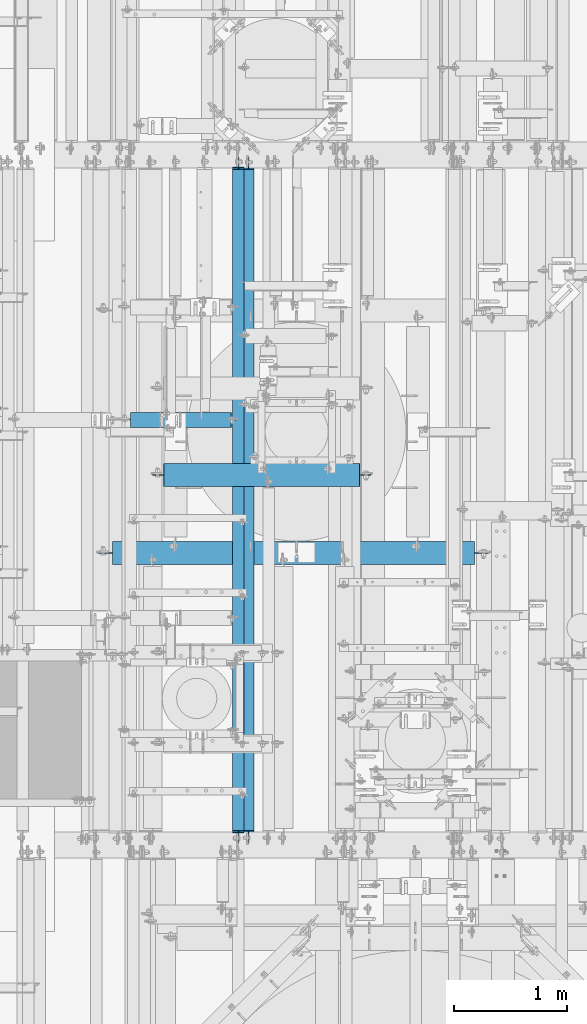
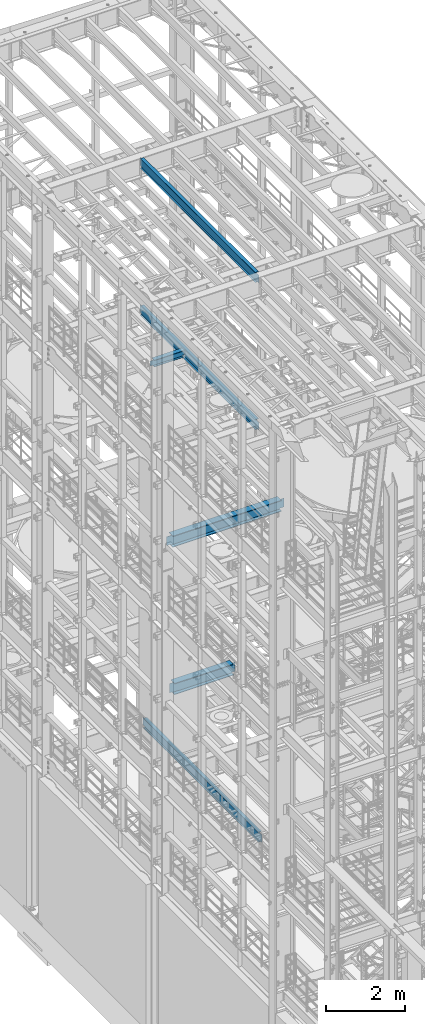
# One storey, part 1025 of 1876: 6 beams, 6 elements without a shape of their own.
"""IFC2X3 building model written with IfcOpenShell, lengths in millimetres."""

from ifc_helpers import new_model, si_unit, frame, origin_with_axes, place, context, subcontext, project, spatial, faceted_brep, material, type_object, element, aggregate, save


model = new_model("IFC2X3")

# Units and contexts
model_context = context("Model", 3, precision=1e-05, world=origin_with_axes())
body_context = subcontext(model_context, "Body", "Model", "MODEL_VIEW")
ifc_project = project(units=[si_unit("LENGTHUNIT", "METRE", prefix="MILLI"), si_unit("AREAUNIT", "SQUARE_METRE"), si_unit("VOLUMEUNIT", "CUBIC_METRE"), si_unit("MASSUNIT", "GRAM", prefix="KILO"), si_unit("TIMEUNIT", "SECOND"), si_unit("PLANEANGLEUNIT", "RADIAN"), si_unit("SOLIDANGLEUNIT", "STERADIAN"), si_unit("THERMODYNAMICTEMPERATUREUNIT", "DEGREE_CELSIUS"), si_unit("LUMINOUSINTENSITYUNIT", "LUMEN")], contexts=[model_context])

# Site, building, storey
site_placement = place(None, origin_with_axes())
site = spatial("IfcSite", under=ifc_project, at=site_placement, CompositionType="ELEMENT")
building_placement = place(site_placement, origin_with_axes())
building = spatial("IfcBuilding", under=site, at=building_placement, Name="Undefined", CompositionType="ELEMENT")
storey_placement = place(building_placement, origin_with_axes())
storey = spatial("IfcBuildingStorey", under=building, at=storey_placement, Name="Undefined", CompositionType="ELEMENT", Elevation=0.0)

# Assembly, beam
assembly_1_placement = place(storey_placement, origin_with_axes())
assembly_1 = element("IfcElementAssembly", 1, at=assembly_1_placement, inside=storey, Name="BEAM", AssemblyPlace="NOTDEFINED", PredefinedType="RIGID_FRAME")
ifc_material = material(Name="STEEL/A992")
beam_type_1 = type_object("IfcBeamType", Name="W12X16", PredefinedType="NOTDEFINED")
beam_1_placement = place(assembly_1_placement, frame((2857.5, 1524.0, 17830.8), z_axis=(0.0, 0.0, 1.0), x_axis=(0.0, 1.0, 0.0)))
beam_1 = element("IfcBeam", 2, at=beam_1_placement, type_object=beam_type_1, material=ifc_material, Name="BEAM", ObjectType="W12X16", context=body_context, shape_type="Brep", body=[
    faceted_brep([(19.84375, -3.17499999999995, -126.999999999996), (19.84375, 3.17499999999995, -126.999999999996), (96.0437501907345, 3.17500002364682, -126.999999999996), (96.0437501907345, -3.17499999999995, -126.999999999996), (100.90382970878, 3.17500002380461, -127.966729922584), (100.90382970878, -3.17499999999995, -127.966729922584), (105.024006176934, 3.17500002425209, -130.719743823061), (105.024006176934, -3.17499999999995, -130.719743823061), (107.777020077412, 3.17500002492102, -134.839920291215), (107.777020077412, -3.17499999999995, -134.839920291215), (108.74375, -3.17499999999995, -139.699999809261), (108.74375, 3.17500002570978, -139.699999809261), (108.74375, 3.17500009516311, -146.049999999999), (108.74375, 50.8, -146.049999999999), (108.74375, 50.8, -152.400000000001), (108.74375, -50.8, -152.400000000001), (108.74375, -50.8, -146.049999999999), (108.74375, -3.17499999999995, -146.049999999999), (5969.79375, 50.8, 146.049999999999), (5969.79375, 3.17499999999995, 146.049999999999), (126.20625, 3.17499999999995, 146.049999999999), (126.20625, 50.8, 146.049999999999), (113.506250190735, -3.17499999999995, 107.950000000004), (113.506250190735, 3.17499998606149, 107.950000000004), (19.84375, 3.17499999999995, 107.950000000004), (19.84375, -3.17499999999995, 107.950000000004), (118.366329708781, -3.17499999999995, 108.916729922592), (118.366329708781, 3.17499998590552, 108.916729922592), (122.486506176934, -3.17499999999995, 111.669743823069), (122.486506176934, 3.17499998546009, 111.669743823069), (125.239520077413, -3.17499999999995, 115.789920291223), (125.239520077413, 3.17499998479298, 115.789920291223), (126.20625, -3.17499999999995, 120.64999980927), (126.20625, 3.17499998400558, 120.64999980927), (5969.79375, -50.8, 152.400000000001), (5969.79375, 50.8, 152.400000000001), (126.20625, 50.8, 152.400000000001), (126.20625, -50.8, 152.400000000001), (5969.79375, -50.8, 146.049999999999), (126.20625, -50.8, 146.049999999999), (5969.79375, -3.17499999999995, 146.049999999999), (126.20625, -3.17499999999995, 146.049999999999), (5969.79375, -3.17499999999995, 120.64999980927), (5969.79375, 3.17499999999995, 120.64999980927), (5970.76047992259, -3.17499999999995, 115.789920291223), (5970.76047992259, 3.17499999999995, 115.789920291223), (5973.51349382307, -3.17499999999995, 111.669743823069), (5973.51349382307, 3.17499999999995, 111.669743823069), (5977.63367029122, -3.17499999999995, 108.916729922592), (5977.63367029122, 3.17499999999995, 108.916729922592), (5982.49374980927, -3.17499999999995, 107.950000000004), (5982.49374980927, 3.17499999999995, 107.950000000004), (6076.15625, -3.17499999999995, 107.950000000004), (6076.15625, 3.17499999999995, 107.950000000004), (6076.15625, -3.17499999999995, -126.999999999996), (6076.15625, 3.17499999999995, -126.999999999996), (5999.95624980926, -3.17499999999995, -126.999999999996), (5999.95624980926, 3.17499999999995, -126.999999999996), (5995.09617029122, -3.17499999999995, -127.966729922584), (5995.09617029122, 3.17499999999995, -127.966729922584), (5990.97599382306, -3.17499999999995, -130.719743823061), (5990.97599382306, 3.17499999999995, -130.719743823061), (5988.22297992259, -3.17499999999995, -134.839920291215), (5988.22297992259, 3.17499999999995, -134.839920291215), (5987.25625, -3.17499999999995, -139.699999809261), (5987.25625, 3.17499999999995, -139.699999809261), (5987.25625, -3.17499999999995, -146.049999999999), (5987.25625, -50.8, -146.049999999999), (5987.25625, -50.8, -152.400000000001), (5987.25625, 50.8, -152.400000000001), (5987.25625, 50.8, -146.049999999999), (5987.25625, 3.17499999999995, -146.049999999999)], [[[0, 1, 2, 3]], [[3, 2, 4, 5]], [[5, 4, 6, 7]], [[7, 6, 8, 9]], [[10, 11, 12, 13, 14, 15, 16, 17]], [[9, 8, 11, 10]], [[18, 19, 20, 21]], [[22, 23, 24, 25]], [[26, 27, 23, 22]], [[28, 29, 27, 26]], [[30, 31, 29, 28]], [[32, 33, 31, 30]], [[34, 35, 36, 37]], [[38, 34, 37, 39]], [[40, 38, 39, 41]], [[37, 36, 21, 20, 33, 32, 41, 39]], [[35, 18, 21, 36]], [[34, 38, 40, 42, 43, 19, 18, 35]], [[44, 45, 43, 42]], [[46, 47, 45, 44]], [[48, 49, 47, 46]], [[50, 51, 49, 48]], [[52, 53, 51, 50]], [[53, 52, 54, 55]], [[54, 56, 57, 55]], [[58, 59, 57, 56]], [[60, 61, 59, 58]], [[62, 63, 61, 60]], [[64, 65, 63, 62]], [[66, 67, 68, 69, 70, 71, 65, 64]], [[67, 66, 17, 16]], [[68, 67, 16, 15]], [[69, 68, 15, 14]], [[70, 69, 14, 13]], [[71, 70, 13, 12]], [[6, 4, 2, 1, 24, 23, 27, 29, 31, 33, 20, 19, 43, 45, 47, 49, 51, 53, 55, 57, 59, 61, 63, 65, 71, 12, 11, 8]], [[25, 24, 1, 0]], [[66, 64, 62, 60, 58, 56, 54, 52, 50, 48, 46, 44, 42, 40, 41, 32, 30, 28, 26, 22, 25, 0, 3, 5, 7, 9, 10, 17]]]),
])
aggregate(assembly_1, [beam_1])

assembly_2_placement = place(storey_placement, origin_with_axes())
assembly_2 = element("IfcElementAssembly", 3, at=assembly_2_placement, inside=storey, Name="BEAM", AssemblyPlace="NOTDEFINED", PredefinedType="RIGID_FRAME")
beam_2_placement = place(assembly_2_placement, frame((2857.5, 1524.0, 22402.8), z_axis=(0.0, 0.0, 1.0), x_axis=(0.0, 1.0, 0.0)))
beam_2 = element("IfcBeam", 4, at=beam_2_placement, type_object=beam_type_1, material=ifc_material, Name="BEAM", ObjectType="W12X16", context=body_context, shape_type="Brep", body=[
    faceted_brep([(19.84375, -3.17499999999995, -126.999999999996), (19.84375, 3.17499999999995, -126.999999999996), (102.393750190735, 3.17500000000018, -127.000000000001), (102.393750190735, -3.17500000000018, -127.000000000001), (107.25382970878, 3.17500000000018, -127.966729922588), (107.25382970878, -3.17500000000018, -127.966729922588), (111.374006176934, 3.17500000000018, -130.719743823067), (111.374006176934, -3.17500000000018, -130.719743823067), (114.127020077412, 3.17500000000018, -134.839920291221), (114.127020077412, -3.17500000000018, -134.839920291221), (115.09375, -3.17500000000018, -139.699999809266), (115.09375, 3.17500000000018, -139.699999809266), (115.09375, 3.17500000000018, -146.05), (115.09375, 50.8000000000002, -146.05), (115.09375, 50.8000000000002, -152.4), (115.09375, -50.8000000000002, -152.4), (115.09375, -50.8000000000002, -146.05), (115.09375, -3.17500000000018, -146.05), (127.79375, 3.17500000000018, 146.05), (127.79375, 50.8000000000002, 146.05), (5968.20625, 50.8, 146.05), (5968.20625, 3.17499999999995, 146.05), (115.093750190735, -3.17500000000018, 114.299999999999), (115.093750190735, 3.17500000000018, 114.299999999999), (19.84375, 3.17500000000018, 114.299999999999), (19.84375, -3.17500000000018, 114.299999999999), (119.95382970878, -3.17500000000018, 115.266729922587), (119.95382970878, 3.17500000000018, 115.266729922587), (124.074006176934, -3.17500000000018, 118.019743823065), (124.074006176934, 3.17500000000018, 118.019743823065), (126.827020077412, -3.17500000000018, 122.139920291219), (126.827020077412, 3.17500000000018, 122.139920291219), (127.79375, -3.17500000000018, 126.999999809264), (127.79375, 3.17500000000018, 126.999999809264), (127.79375, 50.8000000000002, 152.4), (127.79375, -50.8000000000002, 152.4), (5968.20625, -50.8, 152.4), (5968.20625, 50.8, 152.4), (127.79375, -50.8000000000002, 146.05), (5968.20625, -50.8, 146.05), (127.79375, -3.17500000000018, 146.05), (5968.20625, -3.17499999999995, 146.05), (5968.20625, -3.17499999999995, 126.999999809264), (5968.20625, 3.17499999999995, 126.999999809264), (5969.17297992259, -3.17499999999995, 122.139920291219), (5969.17297992259, 3.17499999999995, 122.139920291219), (5971.92599382307, -3.17499999999995, 118.019743823065), (5971.92599382307, 3.17499999999995, 118.019743823065), (5976.04617029122, -3.17499999999995, 115.266729922587), (5976.04617029122, 3.17499999999995, 115.266729922587), (5980.90624980927, -3.17499999999995, 114.299999999999), (5980.90624980927, 3.17499999999995, 114.299999999999), (6076.15625, -3.17499999999995, 114.299999999999), (6076.15625, 3.17499999999995, 114.299999999999), (6076.15625, -3.17499999999995, -126.999999999996), (6076.15625, 3.17499999999995, -126.999999999996), (5993.60624980927, -3.17499999999995, -127.000000000001), (5993.60624980927, 3.17499999999995, -127.000000000001), (5988.74617029122, -3.17499999999995, -127.966729922588), (5988.74617029122, 3.17499999999995, -127.966729922588), (5984.62599382307, -3.17499999999995, -130.719743823067), (5984.62599382307, 3.17499999999995, -130.719743823067), (5981.87297992259, -3.17499999999995, -134.839920291221), (5981.87297992259, 3.17499999999995, -134.839920291221), (5980.90625, -3.17499999999995, -139.699999809266), (5980.90625, 3.17499999999995, -139.699999809266), (5980.90625, -3.17499999999995, -146.05), (5980.90625, -50.8, -146.05), (5980.90625, -50.8, -152.4), (5980.90625, 50.8, -152.4), (5980.90625, 50.8, -146.05), (5980.90625, 3.17499999999995, -146.05)], [[[0, 1, 2, 3]], [[3, 2, 4, 5]], [[5, 4, 6, 7]], [[7, 6, 8, 9]], [[10, 11, 12, 13, 14, 15, 16, 17]], [[9, 8, 11, 10]], [[18, 19, 20, 21]], [[22, 23, 24, 25]], [[26, 27, 23, 22]], [[28, 29, 27, 26]], [[30, 31, 29, 28]], [[32, 33, 31, 30]], [[34, 35, 36, 37]], [[35, 38, 39, 36]], [[38, 40, 41, 39]], [[35, 34, 19, 18, 33, 32, 40, 38]], [[19, 34, 37, 20]], [[36, 39, 41, 42, 43, 21, 20, 37]], [[44, 45, 43, 42]], [[46, 47, 45, 44]], [[48, 49, 47, 46]], [[50, 51, 49, 48]], [[52, 53, 51, 50]], [[53, 52, 54, 55]], [[54, 56, 57, 55]], [[58, 59, 57, 56]], [[60, 61, 59, 58]], [[62, 63, 61, 60]], [[64, 65, 63, 62]], [[66, 67, 68, 69, 70, 71, 65, 64]], [[17, 16, 67, 66]], [[16, 15, 68, 67]], [[15, 14, 69, 68]], [[14, 13, 70, 69]], [[13, 12, 71, 70]], [[59, 61, 63, 65, 71, 12, 11, 8, 6, 4, 2, 1, 24, 23, 27, 29, 31, 33, 18, 21, 43, 45, 47, 49, 51, 53, 55, 57]], [[25, 24, 1, 0]], [[52, 50, 48, 46, 44, 42, 41, 40, 32, 30, 28, 26, 22, 25, 0, 3, 5, 7, 9, 10, 17, 66, 64, 62, 60, 58, 56, 54]]]),
])
aggregate(assembly_2, [beam_2])

assembly_3_placement = place(storey_placement, origin_with_axes())
assembly_3 = element("IfcElementAssembly", 5, at=assembly_3_placement, inside=storey, Name="BEAM", AssemblyPlace="NOTDEFINED", PredefinedType="RIGID_FRAME")
beam_3_placement = place(assembly_3_placement, frame((2946.4, 1524.0, 4978.4), z_axis=(0.0, 0.0, 1.0), x_axis=(0.0, 1.0, 0.0)))
beam_3 = element("IfcBeam", 6, at=beam_3_placement, type_object=beam_type_1, material=ifc_material, Name="BEAM", ObjectType="W12X16", context=body_context, shape_type="Brep", body=[
    faceted_brep([(19.84375, -3.17499999999995, -126.999999999996), (19.84375, 3.17499999999995, -126.999999999996), (102.393750190735, 3.17500000000018, -127.000000000001), (102.393750190735, -3.17500000000018, -127.000000000001), (107.25382970878, 3.17500000000018, -127.966729922588), (107.25382970878, -3.17500000000018, -127.966729922588), (111.374006176934, 3.17500000000018, -130.719743823067), (111.374006176934, -3.17500000000018, -130.719743823067), (114.127020077412, 3.17500000000018, -134.839920291221), (114.127020077412, -3.17500000000018, -134.839920291221), (115.09375, -3.17500000000018, -139.699999809266), (115.09375, 3.17500000000018, -139.699999809266), (115.09375, 3.17500000000018, -146.05), (115.09375, 50.8000000000002, -146.05), (115.09375, 50.8000000000002, -152.4), (115.09375, -50.8000000000002, -152.4), (115.09375, -50.8000000000002, -146.05), (115.09375, -3.17500000000018, -146.05), (127.79375, 3.17500000000018, 146.05), (127.79375, 50.8000000000002, 146.05), (5968.20625, 50.8, 146.05), (5968.20625, 3.17499999999995, 146.05), (115.093750190735, -3.17500000000018, 114.299999999999), (115.093750190735, 3.17500000000018, 114.299999999999), (19.84375, 3.17500000000018, 114.299999999999), (19.84375, -3.17500000000018, 114.299999999999), (119.95382970878, -3.17500000000018, 115.266729922587), (119.95382970878, 3.17500000000018, 115.266729922587), (124.074006176934, -3.17500000000018, 118.019743823065), (124.074006176934, 3.17500000000018, 118.019743823065), (126.827020077412, -3.17500000000018, 122.139920291219), (126.827020077412, 3.17500000000018, 122.139920291219), (127.79375, -3.17500000000018, 126.999999809264), (127.79375, 3.17500000000018, 126.999999809264), (127.79375, 50.8000000000002, 152.4), (127.79375, -50.8000000000002, 152.4), (5968.20625, -50.8, 152.4), (5968.20625, 50.8, 152.4), (127.79375, -50.8000000000002, 146.05), (5968.20625, -50.8, 146.05), (127.79375, -3.17500000000018, 146.05), (5968.20625, -3.17499999999995, 146.05), (5968.20625, -3.17499999999995, 126.999999809264), (5968.20625, 3.17499999999995, 126.999999809264), (5969.17297992259, -3.17499999999995, 122.139920291219), (5969.17297992259, 3.17499999999995, 122.139920291219), (5971.92599382307, -3.17499999999995, 118.019743823065), (5971.92599382307, 3.17499999999995, 118.019743823065), (5976.04617029122, -3.17499999999995, 115.266729922587), (5976.04617029122, 3.17499999999995, 115.266729922587), (5980.90624980927, -3.17499999999995, 114.299999999999), (5980.90624980927, 3.17499999999995, 114.299999999999), (6076.15625, -3.17499999999995, 114.299999999999), (6076.15625, 3.17499999999995, 114.299999999999), (6076.15625, -3.17499999999995, -126.999999999996), (6076.15625, 3.17499999999995, -126.999999999996), (5993.60624980927, -3.17499999999995, -127.000000000001), (5993.60624980927, 3.17499999999995, -127.000000000001), (5988.74617029122, -3.17499999999995, -127.966729922588), (5988.74617029122, 3.17499999999995, -127.966729922588), (5984.62599382307, -3.17499999999995, -130.719743823067), (5984.62599382307, 3.17499999999995, -130.719743823067), (5981.87297992259, -3.17499999999995, -134.839920291221), (5981.87297992259, 3.17499999999995, -134.839920291221), (5980.90625, -3.17499999999995, -139.699999809266), (5980.90625, 3.17499999999995, -139.699999809266), (5980.90625, -3.17499999999995, -146.05), (5980.90625, -50.8, -146.05), (5980.90625, -50.8, -152.4), (5980.90625, 50.8, -152.4), (5980.90625, 50.8, -146.05), (5980.90625, 3.17499999999995, -146.05)], [[[0, 1, 2, 3]], [[3, 2, 4, 5]], [[5, 4, 6, 7]], [[7, 6, 8, 9]], [[10, 11, 12, 13, 14, 15, 16, 17]], [[9, 8, 11, 10]], [[18, 19, 20, 21]], [[22, 23, 24, 25]], [[26, 27, 23, 22]], [[28, 29, 27, 26]], [[30, 31, 29, 28]], [[32, 33, 31, 30]], [[34, 35, 36, 37]], [[35, 38, 39, 36]], [[38, 40, 41, 39]], [[35, 34, 19, 18, 33, 32, 40, 38]], [[19, 34, 37, 20]], [[36, 39, 41, 42, 43, 21, 20, 37]], [[44, 45, 43, 42]], [[46, 47, 45, 44]], [[48, 49, 47, 46]], [[50, 51, 49, 48]], [[52, 53, 51, 50]], [[53, 52, 54, 55]], [[54, 56, 57, 55]], [[58, 59, 57, 56]], [[60, 61, 59, 58]], [[62, 63, 61, 60]], [[64, 65, 63, 62]], [[66, 67, 68, 69, 70, 71, 65, 64]], [[17, 16, 67, 66]], [[16, 15, 68, 67]], [[15, 14, 69, 68]], [[14, 13, 70, 69]], [[13, 12, 71, 70]], [[59, 61, 63, 65, 71, 12, 11, 8, 6, 4, 2, 1, 24, 23, 27, 29, 31, 33, 18, 21, 43, 45, 47, 49, 51, 53, 55, 57]], [[25, 24, 1, 0]], [[52, 50, 48, 46, 44, 42, 41, 40, 32, 30, 28, 26, 22, 25, 0, 3, 5, 7, 9, 10, 17, 66, 64, 62, 60, 58, 56, 54]]]),
])
aggregate(assembly_3, [beam_3])

assembly_4_placement = place(storey_placement, origin_with_axes())
assembly_4 = element("IfcElementAssembly", 7, at=assembly_4_placement, inside=storey, Name="BEAM", AssemblyPlace="NOTDEFINED", PredefinedType="RIGID_FRAME")
beam_type_2 = type_object("IfcBeamType", Name="W8X18", PredefinedType="NOTDEFINED")
beam_4_placement = place(assembly_4_placement, frame((1790.7, 5279.79856567383, 17880.0125), z_axis=(0.0, 0.0, 1.0), x_axis=(1.0, 0.0, 0.0)))
beam_4 = element("IfcBeam", 8, at=beam_4_placement, type_object=beam_type_2, material=ifc_material, Name="BEAM", ObjectType="W8X18", context=body_context, shape_type="Brep", body=[
    faceted_brep([(23.8125, -3.17500000000018, -84.1375000000007), (23.8125, 3.17500000000018, -84.1375000000007), (100.012500190735, 3.17500002374254, -84.1375000000007), (100.012500190735, -3.17500000000018, -84.1375000000007), (104.87257970878, 3.17500002397719, -85.1042299225883), (104.87257970878, -3.17500000000018, -85.1042299225883), (108.992756176934, 3.17500002463203, -87.8572438230658), (108.992756176934, -3.17500000000018, -87.8572438230658), (111.745770077412, 3.17500002560791, -91.9774202912195), (111.745770077412, -3.17500000000018, -91.9774202912195), (112.7125, -66.6750000000002, -96.8374998092659), (112.7125, 66.6750000000002, -96.8374998092659), (112.7125, 66.6750000000002, -103.1875), (112.7125, -66.6750000000002, -103.1875), (112.396726654724, -66.6750000000002, -95.25), (112.396726654724, -3.17500000000018, -95.25), (112.396726654724, 3.17500009399191, -95.25), (112.396726654724, 66.6750000000002, -95.25), (1003.3, -66.6750000000002, 103.1875), (1003.3, 66.6750000000002, 103.1875), (112.7125, 66.6750000000002, 103.1875), (112.7125, -66.6750000000002, 103.1875), (1003.61577334528, -66.6750000000002, 95.25), (1003.3, -66.6750000000002, 96.8374998092695), (112.7125, -66.6750000000002, 95.25), (1003.3, 66.6750000000002, 96.8374998092695), (1003.61577334528, 66.6750000000002, 95.25), (112.7125, 66.6750000000002, 95.25), (1003.61577334528, 3.17500000000018, 95.25), (112.7125, 3.17500000000018, 95.25), (100.012500190735, -3.17500000000018, 71.4375), (100.012500190735, 3.17499998808671, 71.4375), (23.8125, 3.17500000000018, 71.4375), (23.8125, -3.17500000000018, 71.4375), (104.87257970878, -3.17500000000018, 72.4042299225875), (104.87257970878, 3.17499998786207, 72.4042299225875), (108.992756176934, -3.17500000000018, 75.1572438230651), (108.992756176934, 3.17499998721996, 75.1572438230651), (111.745770077412, -3.17500000000018, 79.2774202912187), (111.745770077412, 3.17499998625954, 79.2774202912187), (112.7125, -3.17500000000018, 84.1374998092651), (112.7125, 3.17499998512631, 84.1374998092651), (112.7125, -3.17500000000018, 95.25), (1003.61577334528, -3.17500000000018, 95.25), (1004.26672992259, -3.17500000000018, 91.9774202912231), (1004.26672992259, 3.17500000000018, 91.9774202912231), (1007.01974382307, -3.17500000000018, 87.8572438230694), (1007.01974382307, 3.17500000000018, 87.8572438230694), (1011.13992029122, -3.17500000000018, 85.1042299225919), (1011.13992029122, 3.17500000000018, 85.1042299225919), (1015.99999980927, -3.17500000000018, 84.1375000000044), (1015.99999980927, 3.17500000000018, 84.1375000000044), (1050.925, -3.17500000000018, 84.1375000000044), (1050.925, 3.17500000000018, 84.1375000000044), (1050.925, -3.17500000000018, -77.7874999999949), (1050.925, 3.17500000000018, -77.7874999999949), (971.549999809266, -3.17500000000018, -77.7874999999949), (971.549999809266, 3.17500000000018, -77.7874999999949), (966.68992029122, -3.17500000000018, -78.7542299225825), (966.68992029122, 3.17500000000018, -78.7542299225825), (962.569743823067, -3.17500000000018, -81.50724382306), (962.569743823067, 3.17500000000018, -81.50724382306), (959.816729922588, -3.17500000000018, -85.6274202912136), (959.816729922588, 3.17500000000018, -85.6274202912136), (958.850000000001, -3.17500000000018, -90.48749980926), (958.850000000001, 3.17500000000018, -90.48749980926), (958.850000000001, -3.17500000000018, -95.25), (958.850000000001, -66.6750000000002, -95.25), (958.850000000001, -66.6750000000002, -103.1875), (958.850000000001, 66.6750000000002, -103.1875), (958.850000000001, 66.6750000000002, -95.25), (958.850000000001, 3.17500000000018, -95.25)], [[[0, 1, 2, 3]], [[3, 2, 4, 5]], [[5, 4, 6, 7]], [[7, 6, 8, 9]], [[10, 11, 12, 13]], [[14, 15, 9, 8, 16, 17, 11, 10]], [[18, 19, 20, 21]], [[22, 23, 18, 21, 24]], [[18, 23, 25, 19]], [[19, 25, 26, 27, 20]], [[26, 28, 29, 27]], [[30, 31, 32, 33]], [[34, 35, 31, 30]], [[36, 37, 35, 34]], [[38, 39, 37, 36]], [[40, 41, 39, 38]], [[21, 20, 27, 29, 41, 40, 42, 24]], [[43, 22, 24, 42]], [[44, 45, 28, 26, 25, 23, 22, 43]], [[46, 47, 45, 44]], [[48, 49, 47, 46]], [[50, 51, 49, 48]], [[52, 53, 51, 50]], [[53, 52, 54, 55]], [[54, 56, 57, 55]], [[58, 59, 57, 56]], [[60, 61, 59, 58]], [[62, 63, 61, 60]], [[64, 65, 63, 62]], [[66, 67, 68, 69, 70, 71, 65, 64]], [[69, 68, 13, 12]], [[70, 69, 12, 11, 17]], [[71, 70, 17, 16]], [[6, 4, 2, 1, 32, 31, 35, 37, 39, 41, 29, 28, 45, 47, 49, 51, 53, 55, 57, 59, 61, 63, 65, 71, 16, 8]], [[33, 32, 1, 0]], [[66, 64, 62, 60, 58, 56, 54, 52, 50, 48, 46, 44, 43, 42, 40, 38, 36, 34, 30, 33, 0, 3, 5, 7, 9, 15]], [[67, 66, 15, 14]], [[68, 67, 14, 10, 13]]]),
])
aggregate(assembly_4, [beam_4])

assembly_5_placement = place(storey_placement, origin_with_axes())
assembly_5 = element("IfcElementAssembly", 9, at=assembly_5_placement, inside=storey, Name="BEAM", AssemblyPlace="NOTDEFINED", PredefinedType="RIGID_FRAME")
beam_type_3 = type_object("IfcBeamType", Name="W14X48", PredefinedType="NOTDEFINED")
beam_5_placement = place(assembly_5_placement, frame((1625.6, 4103.6875, 13134.975), z_axis=(0.0, 0.0, 1.0), x_axis=(1.0, 0.0, 0.0)))
beam_5 = element("IfcBeam", 10, at=beam_5_placement, type_object=beam_type_3, material=ifc_material, Name="BEAM", ObjectType="W14X48", context=body_context, shape_type="Brep", body=[
    faceted_brep([(3315.49375, -3.96875, -158.75), (3315.49375, -101.6, -158.75), (3315.49375, -101.6, -174.625), (3315.49375, 101.6, -174.625), (3315.49375, 101.6, -158.75), (3315.49375, 3.96875, -158.75), (3315.49375, 3.96875, -149.224999809267), (3315.49375, -3.96875, -149.224999809267), (3316.46047992259, 3.96875, -144.36492029122), (3316.46047992259, -3.96875, -144.36492029122), (3319.21349382307, 3.96875, -140.244743823067), (3319.21349382307, -3.96875, -140.244743823067), (3323.33367029122, 3.96875, -137.491729922589), (3323.33367029122, -3.96875, -137.491729922589), (3328.19374980927, 3.96875, -136.525000000001), (3328.19374980927, -3.96875, -136.525000000001), (3442.49375, -3.96875, -136.525000000001), (3442.49375, 3.96875, -136.525000000001), (119.85625, 3.96875, 158.75), (119.85625, 101.6, 158.75), (3315.49375, 101.6, 158.75), (3315.49375, 3.96875, 158.75), (119.856250000001, -3.96875, -149.224999809267), (119.856250000001, 3.96875, -149.224999809267), (119.85625, 3.96875, -158.75), (119.85625, 101.6, -158.75), (119.85625, 101.6, -174.625), (119.85625, -101.6, -174.625), (119.85625, -101.6, -158.75), (119.85625, -3.96875, -158.75), (118.889520077413, -3.96875, -144.36492029122), (118.889520077413, 3.96875, -144.36492029122), (116.136506176935, -3.96875, -140.244743823067), (116.136506176935, 3.96875, -140.244743823067), (112.016329708781, -3.96875, -137.491729922589), (112.016329708781, 3.96875, -137.491729922589), (107.156250190735, -3.96875, -136.525000000001), (107.156250190735, 3.96875, -136.525000000001), (-7.1437499999995, -3.96875, -136.525000000001), (-7.1437499999995, 3.96875, -136.525000000001), (-7.1437499999995, -3.96875, 136.524999999998), (-7.1437499999995, 3.96875, 136.524999999998), (107.156250190735, -3.96875, 136.524999999998), (107.156250190735, 3.96875, 136.524999999998), (112.016329708781, -3.96875, 137.491729922585), (112.016329708781, 3.96875, 137.491729922585), (116.136506176935, -3.96875, 140.244743823063), (116.136506176935, 3.96875, 140.244743823063), (118.889520077413, -3.96875, 144.364920291217), (118.889520077413, 3.96875, 144.364920291217), (119.856250000001, -3.96875, 149.224999809263), (119.856250000001, 3.96875, 149.224999809263), (119.85625, -101.6, 174.625), (119.85625, 101.6, 174.625), (119.85625, -3.96875, 158.75), (119.85625, -101.6, 158.75), (3315.49375, -3.96875, 158.75), (3315.49375, -101.6, 158.75), (3315.49375, -101.6, 174.625), (3315.49375, 101.6, 174.625), (3315.49375, -3.96875, 149.224999809263), (3315.49375, 3.96875, 149.224999809263), (3316.46047992259, -3.96875, 144.364920291217), (3316.46047992259, 3.96875, 144.364920291217), (3319.21349382307, -3.96875, 140.244743823063), (3319.21349382307, 3.96875, 140.244743823063), (3323.33367029122, -3.96875, 137.491729922585), (3323.33367029122, 3.96875, 137.491729922585), (3328.19374980927, -3.96875, 136.524999999998), (3328.19374980927, 3.96875, 136.524999999998), (3442.49375, -3.96875, 136.524999999998), (3442.49375, 3.96875, 136.524999999998)], [[[0, 1, 2, 3, 4, 5, 6, 7]], [[7, 6, 8, 9]], [[9, 8, 10, 11]], [[11, 10, 12, 13]], [[13, 12, 14, 15]], [[16, 15, 14, 17]], [[18, 19, 20, 21]], [[22, 23, 24, 25, 26, 27, 28, 29]], [[30, 31, 23, 22]], [[32, 33, 31, 30]], [[34, 35, 33, 32]], [[36, 37, 35, 34]], [[38, 39, 37, 36]], [[40, 41, 39, 38]], [[42, 43, 41, 40]], [[44, 45, 43, 42]], [[46, 47, 45, 44]], [[48, 49, 47, 46]], [[50, 51, 49, 48]], [[52, 53, 19, 18, 51, 50, 54, 55]], [[55, 54, 56, 57]], [[52, 55, 57, 58]], [[53, 52, 58, 59]], [[19, 53, 59, 20]], [[58, 57, 56, 60, 61, 21, 20, 59]], [[62, 63, 61, 60]], [[64, 65, 63, 62]], [[66, 67, 65, 64]], [[68, 69, 67, 66]], [[70, 71, 69, 68]], [[71, 70, 16, 17]], [[12, 10, 8, 6, 5, 24, 23, 31, 33, 35, 37, 39, 41, 43, 45, 47, 49, 51, 18, 21, 61, 63, 65, 67, 69, 71, 17, 14]], [[25, 24, 5, 4]], [[26, 25, 4, 3]], [[27, 26, 3, 2]], [[28, 27, 2, 1]], [[29, 28, 1, 0]], [[70, 68, 66, 64, 62, 60, 56, 54, 50, 48, 46, 44, 42, 40, 38, 36, 34, 32, 30, 22, 29, 0, 7, 9, 11, 13, 15, 16]]]),
])
aggregate(assembly_5, [beam_5])

assembly_6_placement = place(storey_placement, origin_with_axes())
assembly_6 = element("IfcElementAssembly", 11, at=assembly_6_placement, inside=storey, Name="BEAM", AssemblyPlace="NOTDEFINED", PredefinedType="RIGID_FRAME")
beam_6_placement = place(assembly_6_placement, frame((2089.15, 4794.25, 7978.775), z_axis=(0.0, 0.0, 1.0), x_axis=(1.0, 0.0, 0.0)))
beam_6 = element("IfcBeam", 12, at=beam_6_placement, type_object=beam_type_3, material=ifc_material, Name="BEAM", ObjectType="W14X48", context=body_context, shape_type="Brep", body=[
    faceted_brep([(10.3187500000004, -3.96875, -142.875), (10.3187500000004, 3.96875, -142.875), (92.8687501907352, 3.96875, -142.875), (92.8687501907352, -3.96875, -142.875), (97.7288297087807, 3.96875, -143.841729922588), (97.7288297087807, -3.96875, -143.841729922588), (101.849006176934, 3.96875, -146.594743823066), (101.849006176934, -3.96875, -146.594743823066), (104.602020077412, 3.96875, -150.71492029122), (104.602020077412, -3.96875, -150.71492029122), (105.56875, -3.96875, -155.574999809265), (105.56875, 3.96875, -155.574999809265), (105.56875, 3.96875, -158.75), (105.56875, 101.6, -158.75), (105.56875, 101.6, -174.625), (105.56875, -101.6, -174.625), (105.56875, -101.6, -158.75), (105.56875, -3.96875, -158.75), (1837.53087964162, 101.6, 158.75), (1837.53087964162, 3.96875, 158.75), (111.91875, 3.96875, 158.75), (111.91875, 101.6, 158.75), (99.2187501907351, -3.96875, 142.875), (99.2187501907351, 3.96875, 142.875), (10.3187500000004, 3.96875, 142.875), (10.3187500000004, -3.96875, 142.875), (104.078829708781, -3.96875, 143.841729922588), (104.078829708781, 3.96875, 143.841729922588), (108.199006176934, -3.96875, 146.594743823066), (108.199006176934, 3.96875, 146.594743823066), (110.952020077412, -3.96875, 150.71492029122), (110.952020077412, 3.96875, 150.71492029122), (111.91875, -3.96875, 155.574999809265), (111.91875, 3.96875, 155.574999809265), (1837.53087964162, -101.6, 174.625), (1837.53087964162, 101.6, 174.625), (111.91875, 101.6, 174.625), (111.91875, -101.6, 174.625), (1837.53087964162, -101.6, 158.75), (111.91875, -101.6, 158.75), (1837.53087964162, -3.96875, 158.75), (111.91875, -3.96875, 158.75), (1837.53087964162, -3.96875, 155.574999809265), (1837.53087964162, 3.96875, 155.574999809265), (1838.4976095642, -3.96875, 150.71492029122), (1838.4976095642, 3.96875, 150.71492029122), (1841.25062346468, -3.96875, 146.594743823066), (1841.25062346468, 3.96875, 146.594743823066), (1845.37079993284, -3.96875, 143.841729922588), (1845.37079993284, 3.96875, 143.841729922588), (1850.23087945088, -3.96875, 142.875), (1850.23087945088, 3.96875, 142.875), (1939.13087964162, -3.96875, 142.875), (1939.13087964162, 3.96875, 142.875), (1939.13087964162, -3.96875, -142.875), (1939.13087964162, 3.96875, -142.875), (1856.58087945088, -3.96875, -142.875), (1856.58087945088, 3.96875, -142.875), (1851.72079993284, -3.96875, -143.841729922588), (1851.72079993284, 3.96875, -143.841729922588), (1847.60062346468, -3.96875, -146.594743823066), (1847.60062346468, 3.96875, -146.594743823066), (1844.8476095642, -3.96875, -150.71492029122), (1844.8476095642, 3.96875, -150.71492029122), (1843.88087964162, -3.96875, -155.574999809265), (1843.88087964162, 3.96875, -155.574999809265), (1843.88087964162, -3.96875, -158.75), (1843.88087964162, -101.6, -158.75), (1843.88087964162, -101.6, -174.625), (1843.88087964162, 101.6, -174.625), (1843.88087964162, 101.6, -158.75), (1843.88087964162, 3.96875, -158.75)], [[[0, 1, 2, 3]], [[3, 2, 4, 5]], [[5, 4, 6, 7]], [[7, 6, 8, 9]], [[10, 11, 12, 13, 14, 15, 16, 17]], [[9, 8, 11, 10]], [[18, 19, 20, 21]], [[22, 23, 24, 25]], [[26, 27, 23, 22]], [[28, 29, 27, 26]], [[30, 31, 29, 28]], [[32, 33, 31, 30]], [[34, 35, 36, 37]], [[38, 34, 37, 39]], [[40, 38, 39, 41]], [[37, 36, 21, 20, 33, 32, 41, 39]], [[35, 18, 21, 36]], [[34, 38, 40, 42, 43, 19, 18, 35]], [[44, 45, 43, 42]], [[46, 47, 45, 44]], [[48, 49, 47, 46]], [[50, 51, 49, 48]], [[52, 53, 51, 50]], [[53, 52, 54, 55]], [[54, 56, 57, 55]], [[58, 59, 57, 56]], [[60, 61, 59, 58]], [[62, 63, 61, 60]], [[64, 65, 63, 62]], [[66, 67, 68, 69, 70, 71, 65, 64]], [[67, 66, 17, 16]], [[68, 67, 16, 15]], [[69, 68, 15, 14]], [[70, 69, 14, 13]], [[71, 70, 13, 12]], [[6, 4, 2, 1, 24, 23, 27, 29, 31, 33, 20, 19, 43, 45, 47, 49, 51, 53, 55, 57, 59, 61, 63, 65, 71, 12, 11, 8]], [[25, 24, 1, 0]], [[66, 64, 62, 60, 58, 56, 54, 52, 50, 48, 46, 44, 42, 40, 41, 32, 30, 28, 26, 22, 25, 0, 3, 5, 7, 9, 10, 17]]]),
])
aggregate(assembly_6, [beam_6])

save(model, "model.ifc")
